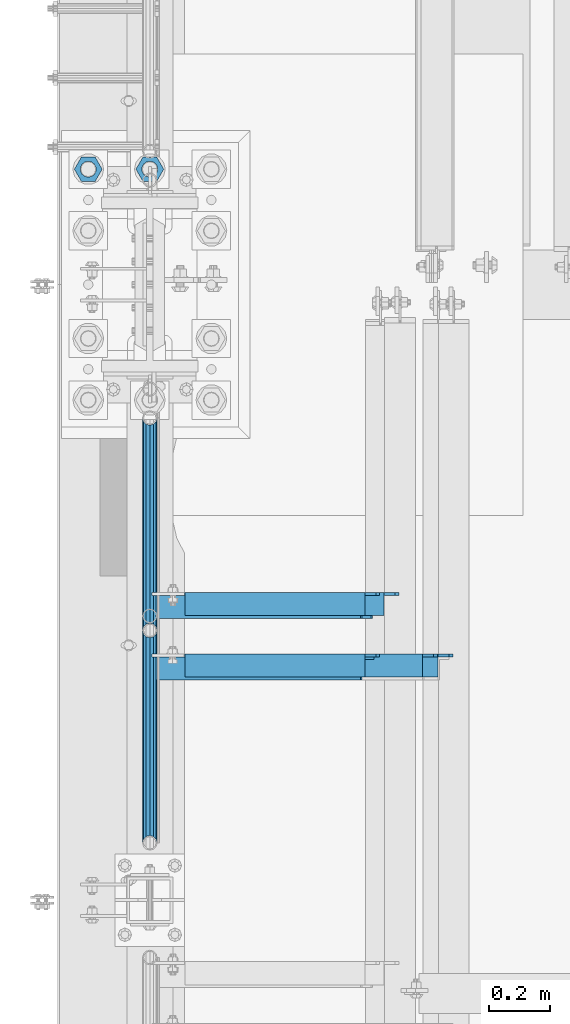
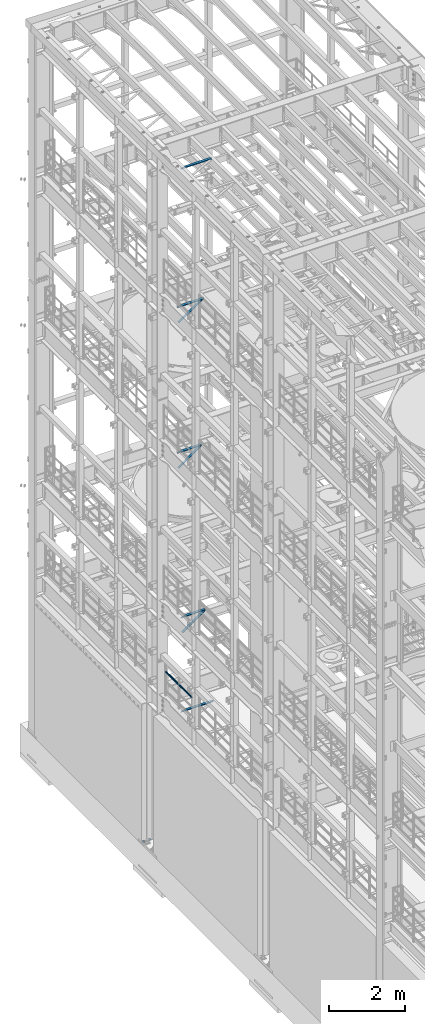
# One storey, part 1286 of 1876: 9 beams, 3 members, 10 elements without a shape of their own.
"""IFC2X3 building model written with IfcOpenShell, lengths in millimetres."""

from ifc_helpers import new_model, si_unit, frame, origin_with_axes, place, context, subcontext, project, spatial, faceted_brep, material, type_object, element, aggregate, save


model = new_model("IFC2X3")

# Units and contexts
model_context = context("Model", 3, precision=1e-05, world=origin_with_axes())
body_context = subcontext(model_context, "Body", "Model", "MODEL_VIEW")
ifc_project = project(units=[si_unit("LENGTHUNIT", "METRE", prefix="MILLI"), si_unit("AREAUNIT", "SQUARE_METRE"), si_unit("VOLUMEUNIT", "CUBIC_METRE"), si_unit("MASSUNIT", "GRAM", prefix="KILO"), si_unit("TIMEUNIT", "SECOND"), si_unit("PLANEANGLEUNIT", "RADIAN"), si_unit("SOLIDANGLEUNIT", "STERADIAN"), si_unit("THERMODYNAMICTEMPERATUREUNIT", "DEGREE_CELSIUS"), si_unit("LUMINOUSINTENSITYUNIT", "LUMEN")], contexts=[model_context])

# Site, building, storey
site_placement = place(None, origin_with_axes())
site = spatial("IfcSite", under=ifc_project, at=site_placement, CompositionType="ELEMENT")
building_placement = place(site_placement, origin_with_axes())
building = spatial("IfcBuilding", under=site, at=building_placement, Name="Undefined", CompositionType="ELEMENT")
storey_placement = place(building_placement, origin_with_axes())
storey = spatial("IfcBuildingStorey", under=building, at=storey_placement, Name="Undefined", CompositionType="ELEMENT", Elevation=0.0)

# Assembly, beams
assembly_1_placement = place(storey_placement, origin_with_axes())
assembly_1 = element("IfcElementAssembly", 1, at=assembly_1_placement, inside=storey, Name="RAIL", AssemblyPlace="NOTDEFINED", PredefinedType="RIGID_FRAME")
ifc_material_1 = material()
beam_type_1 = type_object("IfcBeamType", Name="PIPE1-1/2SCH40", PredefinedType="NOTDEFINED")
beam_1_placement = place(assembly_1_placement, frame((6.68023858452216e-10, 7179.9096633614, 5902.3368245991), z_axis=(0.0, 7.91400000045761e-06, -0.999999999968684), x_axis=(0.0, -0.999999999968684, -7.91400000071008e-06)))
beam_1 = element("IfcBeam", 2, at=beam_1_placement, type_object=beam_type_1, material=ifc_material_1, Name="RAIL", ObjectType="PIPE1-1/2SCH40", context=body_context, shape_type="Brep", body=[
    faceted_brep([(0.0, 24.1299999999992, 0.0), (12.0648982924813, 20.8971929933186, -12.0650000000005), (12.065101708381, 20.8971929933186, 12.0650000000005), (12.065101708381, -20.8971929933186, 12.0650000000005), (12.0648982924813, -20.8971929933186, -12.0650000000005), (0.0, -24.1299999999992, 0.0), (20.897369157401, -12.0649999999996, 20.8971929933205), (20.8973267454676, -12.0649999999277, 15.8661214312533), (15.2546577467156, -17.7076214311801, 10.223500000001), (12.5151929933249, -20.4470000000001, 0.0), (15.2544853785057, -17.7076214311801, -10.2235000000001), (20.8970592426604, -12.0649999999277, -15.8661214312533), (20.8970168307269, -12.0649999999996, -20.8971929933195), (24.1298276326506, 0.0, -20.447000000001), (24.1297965849608, 0.0, -24.130000000001), (21.390472156676, -10.2235000000001, -17.7076214311819), (21.3904721567151, 10.2235000000001, -17.7076214311819), (20.8970592426604, 12.0650000000714, -15.8661214311096), (20.8970168307269, 12.0649999999996, -20.8971929933195), (15.2544853786503, 17.7076214311801, -10.2235000000001), (12.5151929933249, 20.4470000000001, 0.0), (15.2546577468602, 17.7076214311801, 10.223500000001), (20.8973267454676, 12.0650000000714, 15.8661214311096), (20.897369157401, 12.0649999999996, 20.8971929933205), (21.3907707072121, 10.2235000000001, 17.7076214311819), (24.1301723690713, 7.18500814400613e-11, 20.447000000001), (24.1302034167611, 7.18500814400613e-11, 24.1300000000019), (21.390770707173, -10.2235000000001, 17.7076214311819), (701.33983170571, 24.1300000000001, -1.45519152283669e-11), (689.27472999733, 20.8971929933186, -12.0650000000151), (680.442462548309, 12.0649999999996, -20.8971929933323), (701.33983170571, -24.1299999999283, -1.45519152283669e-11), (689.27472999733, -20.8971929933186, -12.0650000000151), (689.27493341323, -20.8971929933186, 12.0649999999878), (680.442814874983, -12.0649999999996, 20.8971929933068), (680.442462548309, -12.0649999999996, -20.8971929933323), (677.20962828895, 0.0, -24.1300000000147), (679.949060998498, 10.2235000000001, -17.7076214311946), (677.20965933664, 0.0, -20.4470000000147), (680.442504960242, 12.0650000000714, -15.8661214311223), (680.442504960242, -12.0649999999277, -15.866121431266), (679.949060998536, -10.2235000000001, -17.7076214311946), (686.085173958994, -17.7076214311801, -10.2235000000137), (688.824638712016, -20.4470000000001, -1.36424205265939e-11), (686.085346327204, -17.7076214311801, 10.2234999999873), (680.44277246305, -12.0649999999277, 15.8661214312397), (679.949359549034, -10.2235000000001, 17.7076214311674), (677.210004073059, 2.72848410531878e-12, 20.4469999999883), (677.210035120749, 2.72848410531878e-12, 24.1299999999883), (680.442814874983, 12.0649999999996, 20.8971929933068), (689.27493341323, 20.8971929933186, 12.0649999999878), (680.44277246305, 12.0650000000714, 15.866121431096), (686.085346327061, 17.7076214311801, 10.2234999999873), (688.824638711873, 20.4470000000001, -1.36424205265939e-11), (686.085173958852, 17.7076214311801, -10.2235000000137), (679.949359548996, 10.2235000000001, 17.7076214311674)], [[[0, 1, 2]], [[3, 4, 5]], [[6, 7, 8, 9, 10, 11, 12, 4, 3]], [[13, 14, 12, 11, 15]], [[16, 17, 18, 14, 13]], [[2, 1, 18, 17, 19, 20, 21, 22, 23]], [[23, 22, 24, 25, 26]], [[26, 25, 27, 7, 6]], [[1, 0, 28, 29]], [[18, 1, 29, 30]], [[31, 32, 33]], [[6, 3, 33, 34]], [[3, 5, 31, 33]], [[5, 4, 32, 31]], [[4, 12, 35, 32]], [[12, 14, 36, 35]], [[14, 18, 30, 36]], [[37, 38, 36, 30, 39]], [[40, 35, 36, 38, 41]], [[33, 32, 35, 40, 42, 43, 44, 45, 34]], [[34, 45, 46, 47, 48]], [[26, 6, 34, 48]], [[2, 23, 49, 50]], [[23, 26, 48, 49]], [[0, 2, 50, 28]], [[28, 50, 29]], [[49, 51, 52, 53, 54, 39, 30, 29, 50]], [[48, 47, 55, 51, 49]], [[25, 24, 55, 47]], [[55, 24, 22, 21, 52, 51]], [[21, 20, 53, 52]], [[20, 19, 54, 53]], [[19, 17, 16, 37, 39, 54]], [[16, 13, 38, 37]], [[13, 15, 41, 38]], [[41, 15, 11, 10, 42, 40]], [[10, 9, 43, 42]], [[9, 8, 44, 43]], [[8, 7, 27, 46, 45, 44]], [[27, 25, 47, 46]]]),
])
beam_2_placement = place(assembly_1_placement, frame((7.03721525496803e-11, 6478.5698316807, 5902.33091229485), z_axis=(0.0, 7.91400000045761e-06, -0.999999999968684), x_axis=(0.0, -0.999999999968684, -7.91400000071008e-06)))
beam_2 = element("IfcBeam", 3, at=beam_2_placement, type_object=beam_type_1, material=ifc_material_1, Name="RAIL", ObjectType="PIPE1-1/2SCH40", context=body_context, shape_type="Brep", body=[
    faceted_brep([(0.0, 24.1299999999992, 0.0), (12.0648982924813, 20.8971929933186, -12.0650000000005), (12.065101708381, 20.8971929933186, 12.0650000000005), (12.065101708381, -20.8971929933186, 12.0650000000005), (12.0648982924813, -20.8971929933186, -12.0650000000005), (0.0, -24.1299999999992, 0.0), (20.897369157401, -12.0649999999996, 20.8971929933205), (20.8973267454676, -12.0649999999277, 15.8661214312533), (15.2546577467156, -17.7076214311801, 10.223500000001), (12.5151929933249, -20.4470000000001, 0.0), (15.2544853785057, -17.7076214311801, -10.2235000000001), (20.8970592426604, -12.0649999999277, -15.8661214312533), (20.8970168307269, -12.0649999999996, -20.8971929933195), (24.1298276326506, 0.0, -20.447000000001), (24.1297965849608, 0.0, -24.130000000001), (21.390472156676, -10.2235000000001, -17.7076214311819), (21.3904721567151, 10.2235000000001, -17.7076214311819), (20.8970592426604, 12.0650000000714, -15.8661214311096), (20.8970168307269, 12.0649999999996, -20.8971929933195), (15.2544853786503, 17.7076214311801, -10.2235000000001), (12.5151929933249, 20.4470000000001, 0.0), (15.2546577468602, 17.7076214311801, 10.223500000001), (20.8973267454676, 12.0650000000714, 15.8661214311096), (20.897369157401, 12.0649999999996, 20.8971929933205), (21.3907707072121, 10.2235000000001, 17.7076214311819), (24.1301723690713, 7.18500814400613e-11, 20.447000000001), (24.1302034167611, 7.18500814400613e-11, 24.1300000000019), (21.390770707173, -10.2235000000001, 17.7076214311819), (701.33983170571, 24.1300000000001, -1.45519152283669e-11), (689.27472999733, 20.8971929933186, -12.0650000000151), (680.442462548309, 12.0649999999996, -20.8971929933323), (701.33983170571, -24.1299999999283, -1.45519152283669e-11), (689.27472999733, -20.8971929933186, -12.0650000000151), (689.27493341323, -20.8971929933186, 12.0649999999878), (680.442814874983, -12.0649999999996, 20.8971929933068), (680.442462548309, -12.0649999999996, -20.8971929933323), (677.20962828895, 0.0, -24.1300000000147), (679.949060998498, 10.2235000000001, -17.7076214311946), (677.20965933664, 0.0, -20.4470000000147), (680.442504960242, 12.0650000000714, -15.8661214311223), (680.442504960242, -12.0649999999277, -15.866121431266), (679.949060998536, -10.2235000000001, -17.7076214311946), (686.085173958994, -17.7076214311801, -10.2235000000137), (688.824638712016, -20.4470000000001, -1.36424205265939e-11), (686.085346327204, -17.7076214311801, 10.2234999999873), (680.44277246305, -12.0649999999277, 15.8661214312397), (679.949359549034, -10.2235000000001, 17.7076214311674), (677.210004073059, 2.72848410531878e-12, 20.4469999999883), (677.210035120749, 2.72848410531878e-12, 24.1299999999883), (680.442814874983, 12.0649999999996, 20.8971929933068), (689.27493341323, 20.8971929933186, 12.0649999999878), (680.44277246305, 12.0650000000714, 15.866121431096), (686.085346327061, 17.7076214311801, 10.2234999999873), (688.824638711873, 20.4470000000001, -1.36424205265939e-11), (686.085173958852, 17.7076214311801, -10.2235000000137), (679.949359548996, 10.2235000000001, 17.7076214311674)], [[[0, 1, 2]], [[3, 4, 5]], [[6, 7, 8, 9, 10, 11, 12, 4, 3]], [[13, 14, 12, 11, 15]], [[16, 17, 18, 14, 13]], [[2, 1, 18, 17, 19, 20, 21, 22, 23]], [[23, 22, 24, 25, 26]], [[26, 25, 27, 7, 6]], [[1, 0, 28, 29]], [[18, 1, 29, 30]], [[31, 32, 33]], [[6, 3, 33, 34]], [[3, 5, 31, 33]], [[5, 4, 32, 31]], [[4, 12, 35, 32]], [[12, 14, 36, 35]], [[14, 18, 30, 36]], [[37, 38, 36, 30, 39]], [[40, 35, 36, 38, 41]], [[33, 32, 35, 40, 42, 43, 44, 45, 34]], [[34, 45, 46, 47, 48]], [[26, 6, 34, 48]], [[2, 23, 49, 50]], [[23, 26, 48, 49]], [[0, 2, 50, 28]], [[28, 50, 29]], [[49, 51, 52, 53, 54, 39, 30, 29, 50]], [[48, 47, 55, 51, 49]], [[25, 24, 55, 47]], [[55, 24, 22, 21, 52, 51]], [[21, 20, 53, 52]], [[20, 19, 54, 53]], [[19, 17, 16, 37, 39, 54]], [[16, 13, 38, 37]], [[13, 15, 41, 38]], [[41, 15, 11, 10, 42, 40]], [[10, 9, 43, 42]], [[9, 8, 44, 43]], [[8, 7, 27, 46, 45, 44]], [[27, 25, 47, 46]]]),
])
aggregate(assembly_1, [beam_1, beam_2])

# Assembly, member
assembly_2_placement = place(storey_placement, origin_with_axes())
assembly_2 = element("IfcElementAssembly", 4, at=assembly_2_placement, inside=storey, AssemblyPlace="NOTDEFINED", PredefinedType="RIGID_FRAME")
ifc_material_2 = material(Name="STEEL/A36")
member_type = type_object("IfcMemberType", Name="L3X3X3/8", PredefinedType="NOTDEFINED")
member_1_placement = place(assembly_2_placement, frame((21.6869001657126, 6556.375, 17424.2669187563), z_axis=(0.0, -1.0, 0.0), x_axis=(0.822192192147785, 0.0, 0.569209978102299)))
member_1 = element("IfcMember", 5, at=member_1_placement, type_object=member_type, material=ifc_material_2, ObjectType="L3X3X3/8", context=body_context, shape_type="Brep", body=[
    faceted_brep([(24.1351720308776, 38.0999999999403, -38.1000000000004), (24.1351720308776, 38.0999999999403, 38.0999999999999), (887.866654075793, 38.0999999989017, 38.0999999999999), (887.866654075793, 38.0999999989017, -38.1000000000004), (24.135172030894, 28.5749999999462, 38.0999999999999), (887.866654075808, 28.5749999989075, 38.0999999999999), (24.135172030894, 28.5749999999462, -28.5749999999998), (887.866654075808, 28.5749999989075, -28.5749999999998), (24.1351720310122, -38.0999999999985, -28.5749999999998), (887.86665407593, -38.1000000010354, -28.5749999999998), (24.1351720310122, -38.0999999999985, -38.1000000000004), (887.86665407593, -38.1000000010354, -38.1000000000004)], [[[0, 1, 2, 3]], [[1, 4, 5, 2]], [[4, 6, 7, 5]], [[6, 8, 9, 7]], [[8, 10, 11, 9]], [[10, 0, 3, 11]], [[5, 7, 9, 11, 3, 2]], [[10, 8, 6, 4, 1, 0]]]),
])
aggregate(assembly_2, [member_1])

assembly_3_placement = place(storey_placement, origin_with_axes())
assembly_3 = element("IfcElementAssembly", 6, at=assembly_3_placement, inside=storey, AssemblyPlace="NOTDEFINED", PredefinedType="RIGID_FRAME")
member_2_placement = place(assembly_3_placement, frame((22.1939709589552, 6353.175, 7601.73169287095), z_axis=(0.0, -1.0, 0.0), x_axis=(0.812817140855119, 0.0, 0.582518922896166)))
member_2 = element("IfcMember", 7, at=member_2_placement, type_object=member_type, material=ifc_material_2, ObjectType="L3X3X3/8", context=body_context, shape_type="Brep", body=[
    faceted_brep([(24.4135476554111, 38.1000000000058, -38.0999999999999), (24.4135476554111, 38.1000000000058, 38.0999999999999), (855.72322987264, 38.1000000000749, 38.0999999999999), (855.72322987264, 38.1000000000749, -38.0999999999999), (24.4135476554093, 28.5750000000053, 38.0999999999999), (855.723229872639, 28.5750000000744, 38.0999999999999), (24.4135476554093, 28.5750000000053, -28.5749999999998), (855.723229872639, 28.5750000000744, -28.5749999999998), (24.4135476553975, -38.1000000000031, -28.5749999999998), (855.723229872628, -38.0999999999331, -28.5749999999998), (24.4135476553975, -38.1000000000031, -38.0999999999999), (855.723229872628, -38.0999999999331, -38.0999999999999)], [[[0, 1, 2, 3]], [[1, 4, 5, 2]], [[4, 6, 7, 5]], [[6, 8, 9, 7]], [[8, 10, 11, 9]], [[10, 0, 3, 11]], [[5, 7, 9, 11, 3, 2]], [[10, 8, 6, 4, 1, 0]]]),
])
aggregate(assembly_3, [member_2])

assembly_4_placement = place(storey_placement, origin_with_axes())
assembly_4 = element("IfcElementAssembly", 8, at=assembly_4_placement, inside=storey, Name="BRACE", AssemblyPlace="NOTDEFINED", PredefinedType="RIGID_FRAME")
member_3_placement = place(assembly_4_placement, frame((22.1939716658251, 6556.375, 12757.9316674293), z_axis=(0.0, -1.0, 0.0), x_axis=(0.812817140855119, 0.0, 0.582518922896166)))
member_3 = element("IfcMember", 9, at=member_3_placement, type_object=member_type, material=ifc_material_2, Name="BRACE", ObjectType="L3X3X3/8", context=body_context, shape_type="Brep", body=[
    faceted_brep([(855.723229872639, 28.5750000000744, 38.0999999999999), (855.723229872639, 28.5750000000744, -28.5749999999998), (855.723229872628, -38.0999999999331, -28.5749999999998), (855.723229872628, -38.0999999999331, -38.0999999999999), (855.72322987264, 38.1000000000749, -38.0999999999999), (855.72322987264, 38.1000000000749, 38.0999999999999), (24.4135476554093, 28.5750000000053, 38.0999999999999), (24.4135476554093, 28.5750000000053, -28.5749999999998), (24.4135476553975, -38.1000000000031, -28.5749999999998), (24.4135476553975, -38.1000000000031, -38.0999999999999), (24.4135476554111, 38.1000000000058, -38.0999999999999), (24.4135476554111, 38.1000000000058, 38.0999999999999)], [[[0, 1, 2, 3, 4, 5]], [[6, 7, 1, 0]], [[7, 8, 2, 1]], [[8, 9, 3, 2]], [[9, 10, 4, 3]], [[10, 11, 5, 4]], [[11, 6, 0, 5]], [[9, 8, 7, 6, 11, 10]]]),
])
aggregate(assembly_4, [member_3])

# Assembly, beam
assembly_5_placement = place(storey_placement, origin_with_axes())
assembly_5 = element("IfcElementAssembly", 10, at=assembly_5_placement, inside=storey, Name="ANGLE", AssemblyPlace="NOTDEFINED", PredefinedType="RIGID_FRAME")
beam_type_2 = type_object("IfcBeamType", Name="L3X3X3/8", PredefinedType="NOTDEFINED")
beam_3_placement = place(assembly_5_placement, frame((4.51516825708356e-09, 6362.7, 22517.1), z_axis=(0.0, -1.0, 0.0), x_axis=(1.0, 0.0, 0.0)))
beam_3 = element("IfcBeam", 11, at=beam_3_placement, type_object=beam_type_2, material=ifc_material_2, Name="ANGLE", ObjectType="L3X3X3/8", context=body_context, shape_type="Brep", body=[
    faceted_brep([(115.886999817316, 28.5750000000007, 38.0999999999999), (115.886999817316, 38.0999999999985, 38.0999999999999), (115.886998826692, 38.0999999999985, -38.0999999999999), (115.88699882669, 12.699999237062, -38.0999999999999), (115.886998950515, 12.699999237062, -28.5749999999998), (115.88699895052, 28.5750000000007, -28.5749999999998), (38.8937432114558, 12.699999237062, -38.0999999999999), (38.8937433352807, 12.699999237062, -28.5749999999998), (7.14374321145577, -19.050000762938, -38.0999999999999), (7.14374333528067, -19.050000762938, -28.5749999999998), (7.1437499954859, -38.0999999999985, -38.0999999999999), (7.1437499954859, -38.0999999999985, -28.5749999999998), (949.325002419604, 15.8750003814712, -28.5749999999998), (936.625002610339, 28.5750000000007, -28.5749999999998), (900.113000619098, 28.5750000000007, -28.5749999999998), (949.324999995485, -38.0999999999985, -28.5749999999998), (949.325002419604, 3.17500152588036, -28.5749999999998), (900.11300241932, 28.5750000000007, 38.0999999999999), (900.1130024193, 38.0999999999985, 38.0999999999999), (900.113000361957, 38.0999999999985, -38.0999999999999), (900.113000361924, 28.5750001907363, -38.0999999999999), (936.625002353164, 28.5750001907363, -38.0999999999999), (949.325002162429, 15.8750003814712, -38.0999999999999), (949.325002162429, 3.17500152588036, -38.0999999999999), (949.324999995485, -38.0999999999985, -38.0999999999999)], [[[0, 1, 2, 3, 4, 5]], [[4, 3, 6, 7]], [[7, 6, 8, 9]], [[8, 10, 11, 9]], [[12, 13, 14, 5, 4, 7, 9, 11, 15, 16]], [[0, 5, 14, 17]], [[1, 0, 17, 18]], [[2, 1, 18, 19]], [[17, 14, 20, 19, 18]], [[13, 21, 20, 14]], [[12, 22, 21, 13]], [[16, 23, 22, 12]], [[10, 8, 6, 3, 2, 19, 20, 21, 22, 23, 24]], [[11, 10, 24, 15]], [[23, 16, 15, 24]]]),
])
aggregate(assembly_5, [beam_3])

assembly_6_placement = place(storey_placement, origin_with_axes())
assembly_6 = element("IfcElementAssembly", 12, at=assembly_6_placement, inside=storey, Name="ANGLE", AssemblyPlace="NOTDEFINED", PredefinedType="RIGID_FRAME")
beam_4_placement = place(assembly_6_placement, frame((-1.44313229599957e-09, 6565.9, 17945.1), z_axis=(0.0, -1.0, 0.0), x_axis=(1.0, 0.0, 0.0)))
beam_4 = element("IfcBeam", 13, at=beam_4_placement, type_object=beam_type_2, material=ifc_material_2, Name="ANGLE", ObjectType="L3X3X3/8", context=body_context, shape_type="Brep", body=[
    faceted_brep([(773.112500001443, 28.5750000000007, 38.0999999999999), (773.112500001443, 28.5750000000007, -28.5749999999998), (773.112500001443, 28.5750000000007, -38.1000000000004), (773.112500001443, 38.0999999999985, -38.1000000000004), (773.112500001443, 38.0999999999985, 38.0999999999999), (809.625001718057, 28.5750000000007, -28.5749999999998), (809.625001718057, 28.5750000000007, -38.1000000000004), (822.325001527322, 15.8750001907356, -28.5749999999998), (822.325001527322, 15.8750001907356, -38.1000000000004), (822.325001527322, -38.1000030517571, -28.5749999999998), (822.325001527322, -38.0999999999985, -38.1000000000004), (115.886999817316, 28.5750000000007, 38.0999999999999), (115.886999817316, 38.0999999999985, 38.0999999999999), (115.886998826692, 38.0999999999985, -38.0999999999999), (115.88699882669, 12.699999237062, -38.0999999999999), (115.886998950515, 12.699999237062, -28.5749999999998), (115.88699895052, 28.5750000000007, -28.5749999999998), (38.8937432114558, 12.699999237062, -38.0999999999999), (38.8937433352807, 12.699999237062, -28.5749999999998), (7.14374321145577, -19.050000762938, -38.0999999999999), (7.14374333528067, -19.050000762938, -28.5749999999998), (7.1437499954859, -38.0999999999985, -38.0999999999999), (7.1437499954859, -38.0999999999985, -28.5749999999998)], [[[0, 1, 2, 3, 4]], [[5, 6, 2, 1]], [[7, 8, 6, 5]], [[9, 10, 8, 7]], [[11, 12, 13, 14, 15, 16]], [[15, 14, 17, 18]], [[18, 17, 19, 20]], [[19, 21, 22, 20]], [[9, 7, 5, 1, 16, 15, 18, 20, 22]], [[1, 0, 11, 16]], [[0, 4, 12, 11]], [[4, 3, 13, 12]], [[17, 14, 13, 3, 2, 6, 8, 10, 21, 19]], [[10, 9, 22, 21]]]),
])
aggregate(assembly_6, [beam_4])

assembly_7_placement = place(storey_placement, origin_with_axes())
assembly_7 = element("IfcElementAssembly", 14, at=assembly_7_placement, inside=storey, Name="ANGLE", AssemblyPlace="NOTDEFINED", PredefinedType="RIGID_FRAME")
beam_5_placement = place(assembly_7_placement, frame((0.0, 6362.7, 8115.3), z_axis=(0.0, -1.0, 0.0), x_axis=(1.0, 0.0, 0.0)))
beam_5 = element("IfcBeam", 15, at=beam_5_placement, type_object=beam_type_2, material=ifc_material_2, Name="ANGLE", ObjectType="L3X3X3/8", context=body_context, shape_type="Brep", body=[
    faceted_brep([(115.886999817316, 28.5750000000007, 38.0999999999999), (115.886999817316, 38.0999999999985, 38.0999999999999), (115.886998826692, 38.0999999999985, -38.0999999999999), (115.88699882669, 12.699999237062, -38.0999999999999), (115.886998950515, 12.699999237062, -28.5749999999998), (115.88699895052, 28.5750000000007, -28.5749999999998), (38.8937432114558, 12.699999237062, -38.0999999999999), (38.8937433352807, 12.699999237062, -28.5749999999998), (7.14374321145577, -19.050000762938, -38.0999999999999), (7.14374333528067, -19.050000762938, -28.5749999999998), (7.1437499954859, -38.0999999999985, -38.0999999999999), (7.1437499954859, -38.0999999999985, -28.5749999999998), (758.825002424117, 15.8750003814712, -28.5749999999998), (746.125002614852, 28.5749999999998, -28.5749999999998), (709.61300062358, 28.5749999999998, -28.5749999999998), (758.824999999999, -38.1000000000004, -28.5749999999998), (758.825002424117, 3.17500152588036, -28.5749999999998), (709.613002423808, 28.5749999999998, 38.1000000000004), (709.613002423808, 38.1000000000004, 38.1000000000004), (709.613000366395, 38.1000000000004, -38.1000000000004), (709.613000366404, 28.5750001907363, -38.1000000000004), (746.125002357676, 28.5750001907363, -38.1000000000004), (758.825002166941, 15.8750003814712, -38.1000000000004), (758.825002166941, 3.17500152588036, -38.1000000000004), (758.824999999999, -38.1000000000004, -38.1000000000004)], [[[0, 1, 2, 3, 4, 5]], [[4, 3, 6, 7]], [[7, 6, 8, 9]], [[8, 10, 11, 9]], [[12, 13, 14, 5, 4, 7, 9, 11, 15, 16]], [[0, 5, 14, 17]], [[1, 0, 17, 18]], [[2, 1, 18, 19]], [[17, 14, 20, 19, 18]], [[13, 21, 20, 14]], [[12, 22, 21, 13]], [[16, 23, 22, 12]], [[10, 8, 6, 3, 2, 19, 20, 21, 22, 23, 24]], [[11, 10, 24, 15]], [[23, 16, 15, 24]]]),
])
aggregate(assembly_7, [beam_5])

assembly_8_placement = place(storey_placement, origin_with_axes())
assembly_8 = element("IfcElementAssembly", 16, at=assembly_8_placement, inside=storey, Name="ANGLE", AssemblyPlace="NOTDEFINED", PredefinedType="RIGID_FRAME")
beam_6_placement = place(assembly_8_placement, frame((0.0, 6362.7, 5092.7), z_axis=(0.0, -1.0, 0.0), x_axis=(1.0, 0.0, 0.0)))
beam_6 = element("IfcBeam", 17, at=beam_6_placement, type_object=beam_type_2, material=ifc_material_2, Name="ANGLE", ObjectType="L3X3X3/8", context=body_context, shape_type="Brep", body=[
    faceted_brep([(115.886999817316, 28.5750000000007, 38.0999999999999), (115.886999817316, 38.0999999999985, 38.0999999999999), (115.886998826692, 38.0999999999985, -38.0999999999999), (115.88699882669, 12.699999237062, -38.0999999999999), (115.886998950515, 12.699999237062, -28.5749999999998), (115.88699895052, 28.5750000000007, -28.5749999999998), (38.8937432114558, 12.699999237062, -38.0999999999999), (38.8937433352807, 12.699999237062, -28.5749999999998), (7.14374321145577, -19.050000762938, -38.0999999999999), (7.14374333528067, -19.050000762938, -28.5749999999998), (7.1437499954859, -38.0999999999985, -38.0999999999999), (7.1437499954859, -38.0999999999985, -28.5749999999998), (1000.12500242412, 15.8750003814712, -28.5749999999998), (987.425002614851, 28.5749999999998, -28.5749999999998), (950.913000303442, 28.5749999999998, -28.5749999999998), (1000.12500001551, -38.1000000000004, -28.5749999999998), (1000.12500242412, 3.17500152588036, -28.5749999999998), (950.913001170238, 28.5749999999998, 38.0999999999999), (950.913001170238, 38.1000000000004, 38.0999999999999), (950.913000179614, 38.1000000000004, -38.0999999999999), (950.913000366403, 28.5750001907363, -38.0999999999999), (987.425002357675, 28.5750001907363, -38.0999999999999), (1000.12500216694, 15.8750003814712, -38.0999999999999), (1000.12500216694, 3.17500152588036, -38.0999999999999), (1000.12500001551, -38.1000000000004, -38.0999999999999)], [[[0, 1, 2, 3, 4, 5]], [[4, 3, 6, 7]], [[7, 6, 8, 9]], [[8, 10, 11, 9]], [[12, 13, 14, 5, 4, 7, 9, 11, 15, 16]], [[0, 5, 14, 17]], [[1, 0, 17, 18]], [[2, 1, 18, 19]], [[17, 14, 20, 19, 18]], [[13, 21, 20, 14]], [[12, 22, 21, 13]], [[16, 23, 22, 12]], [[10, 8, 6, 3, 2, 19, 20, 21, 22, 23, 24]], [[11, 10, 24, 15]], [[23, 16, 15, 24]]]),
])
aggregate(assembly_8, [beam_6])

assembly_9_placement = place(storey_placement, origin_with_axes())
assembly_9 = element("IfcElementAssembly", 18, at=assembly_9_placement, inside=storey, Name="ANGLE", AssemblyPlace="NOTDEFINED", PredefinedType="RIGID_FRAME")
beam_7_placement = place(assembly_9_placement, frame((-8.61482369428009e-09, 6565.9, 13271.5), z_axis=(0.0, -1.0, 0.0), x_axis=(1.0, 0.0, 0.0)))
beam_7 = element("IfcBeam", 19, at=beam_7_placement, type_object=beam_type_2, material=ifc_material_2, Name="ANGLE", ObjectType="L3X3X3/8", context=body_context, shape_type="Brep", body=[
    faceted_brep([(115.886999817316, 28.5750000000007, 38.0999999999999), (115.886999817316, 38.0999999999985, 38.0999999999999), (115.886998826692, 38.0999999999985, -38.0999999999999), (115.88699882669, 12.699999237062, -38.0999999999999), (115.886998950515, 12.699999237062, -28.5749999999998), (115.88699895052, 28.5750000000007, -28.5749999999998), (38.8937432114558, 12.699999237062, -38.0999999999999), (38.8937433352807, 12.699999237062, -28.5749999999998), (7.14374321145577, -19.050000762938, -38.0999999999999), (7.14374333528067, -19.050000762938, -28.5749999999998), (7.1437499954859, -38.0999999999985, -38.0999999999999), (7.1437499954859, -38.0999999999985, -28.5749999999998), (758.82500204062, 14.2880005577626, -28.5749999999998), (746.125002396449, 26.9880005321429, -28.5749999999998), (709.613000600291, 26.9880010068428, -28.5749999999998), (709.61300062358, 28.5749999999998, -28.5749999999998), (758.824999999999, -38.1000000000004, -28.5749999999998), (758.825001875526, 1.58799979482319, -28.5749999999998), (709.613002423808, 28.5749999999998, 38.1000000000004), (709.613002423808, 38.1000000000004, 38.1000000000004), (709.613000366395, 38.1000000000004, -38.1000000000004), (709.613000343115, 26.9880010068428, -38.1000000000004), (746.125002139273, 26.9880005321429, -38.1000000000004), (758.825001783445, 14.2880005577626, -38.1000000000004), (758.825001618351, 1.58799979482319, -38.1000000000004), (758.824999999999, -38.1000000000004, -38.1000000000004)], [[[0, 1, 2, 3, 4, 5]], [[4, 3, 6, 7]], [[7, 6, 8, 9]], [[8, 10, 11, 9]], [[12, 13, 14, 15, 5, 4, 7, 9, 11, 16, 17]], [[0, 5, 15, 18]], [[1, 0, 18, 19]], [[2, 1, 19, 20]], [[18, 15, 14, 21, 20, 19]], [[13, 22, 21, 14]], [[12, 23, 22, 13]], [[17, 24, 23, 12]], [[10, 8, 6, 3, 2, 20, 21, 22, 23, 24, 25]], [[11, 10, 25, 16]], [[24, 17, 16, 25]]]),
])
aggregate(assembly_9, [beam_7])

# Assembly, beams
assembly_10_placement = place(storey_placement, origin_with_axes())
assembly_10 = element("IfcElementAssembly", 20, at=assembly_10_placement, inside=storey, Name="TEMPLATE", AssemblyPlace="NOTDEFINED", PredefinedType="RIGID_FRAME")
ifc_material_3 = material(Name="STEEL/A563")
beam_type_3 = type_object("IfcBeamType", Name="2_DIA. HALF_NUT", PredefinedType="NOTDEFINED")
beam_8_placement = place(assembly_10_placement, frame((-203.2, 8000.99999847412, 33.3375), z_axis=(0.0, -1.0, 0.0), x_axis=(0.0, 0.0, -1.0)))
beam_8 = element("IfcBeam", 21, at=beam_8_placement, type_object=beam_type_3, material=ifc_material_3, Name="NUT", ObjectType="2_DIA. HALF_NUT", context=body_context, shape_type="Brep", body=[
    faceted_brep([(0.0, -46.0369987487793, 9.09494701772928e-13), (0.0, -23.0184993743896, -39.869213104248), (25.4, -23.0184993743896, -39.869213104248), (25.4, -46.0369987487793, 9.09494701772928e-13), (0.0, 23.0184993743896, -39.869213104248), (25.4, 23.0184993743896, -39.869213104248), (0.0, 46.0369987487793, -9.09494701772928e-13), (25.4, 46.0369987487793, -9.09494701772928e-13), (0.0, 23.0184993743896, 39.869213104248), (25.4, 23.0184993743896, 39.869213104248), (0.0, -23.0184993743896, 39.869213104248), (25.4, -23.0184993743896, 39.869213104248), (0.0, 0.0, 26.1940002441406), (0.0, 11.3650617044514, 23.5999013092769), (25.4, 11.3650617044514, 23.5999013092769), (25.4, 0.0, 26.1940002441406), (0.0, 20.4791109456437, 16.3316083006703), (25.4, 20.4791109456437, 16.3316083006703), (0.0, 25.5370200498346, 5.82867859874477), (25.4, 25.5370200498346, 5.82867859874477), (0.0, 25.5370200498346, -5.82867859874477), (25.4, 25.5370200498346, -5.82867859874477), (0.0, 20.4791109456437, -16.3316083006703), (25.4, 20.4791109456437, -16.3316083006703), (0.0, 11.3650617044514, -23.5999013092769), (25.4, 11.3650617044514, -23.5999013092769), (0.0, 0.0, -26.1940002441406), (25.4, 0.0, -26.1940002441406), (0.0, -11.3650617044514, -23.5999013092769), (25.4, -11.3650617044514, -23.5999013092769), (0.0, -20.4791109456437, -16.3316083006703), (25.4, -20.4791109456437, -16.3316083006703), (0.0, -25.5370200498346, -5.82867859874477), (25.4, -25.5370200498346, -5.82867859874477), (0.0, -25.5370200498346, 5.82867859874477), (25.4, -25.5370200498346, 5.82867859874477), (0.0, -20.4791109456437, 16.3316083006703), (25.4, -20.4791109456437, 16.3316083006703), (0.0, -11.3650617044514, 23.5999013092769), (25.4, -11.3650617044514, 23.5999013092769)], [[[0, 1, 2, 3]], [[1, 4, 5, 2]], [[4, 6, 7, 5]], [[6, 8, 9, 7]], [[8, 10, 11, 9]], [[10, 0, 3, 11]], [[12, 13, 14, 15]], [[13, 16, 17, 14]], [[16, 18, 19, 17]], [[18, 20, 21, 19]], [[20, 22, 23, 21]], [[22, 24, 25, 23]], [[24, 26, 27, 25]], [[26, 28, 29, 27]], [[28, 30, 31, 29]], [[30, 32, 33, 31]], [[32, 34, 35, 33]], [[34, 36, 37, 35]], [[36, 38, 39, 37]], [[38, 12, 15, 39]], [[5, 7, 9, 11, 3, 2], [17, 19, 21, 23, 25, 27, 29, 31, 33, 35, 37, 39, 15, 14]], [[10, 8, 6, 4, 1, 0], [38, 36, 34, 32, 30, 28, 26, 24, 22, 20, 18, 16, 13, 12]]]),
])
beam_9_placement = place(assembly_10_placement, frame((0.0, 8000.99999847412, 33.3375), z_axis=(0.0, -1.0, 0.0), x_axis=(0.0, 0.0, -1.0)))
beam_9 = element("IfcBeam", 22, at=beam_9_placement, type_object=beam_type_3, material=ifc_material_3, Name="NUT", ObjectType="2_DIA. HALF_NUT", context=body_context, shape_type="Brep", body=[
    faceted_brep([(0.0, -46.0369987487793, 9.09494701772928e-13), (0.0, -23.0184993743896, -39.869213104248), (25.4, -23.0184993743896, -39.869213104248), (25.4, -46.0369987487793, 9.09494701772928e-13), (0.0, 23.0184993743896, -39.869213104248), (25.4, 23.0184993743896, -39.869213104248), (0.0, 46.0369987487793, -9.09494701772928e-13), (25.4, 46.0369987487793, -9.09494701772928e-13), (0.0, 23.0184993743896, 39.869213104248), (25.4, 23.0184993743896, 39.869213104248), (0.0, -23.0184993743896, 39.869213104248), (25.4, -23.0184993743896, 39.869213104248), (0.0, 0.0, 26.1940002441406), (0.0, 11.3650617044514, 23.5999013092769), (25.4, 11.3650617044514, 23.5999013092769), (25.4, 0.0, 26.1940002441406), (0.0, 20.4791109456437, 16.3316083006703), (25.4, 20.4791109456437, 16.3316083006703), (0.0, 25.5370200498346, 5.82867859874477), (25.4, 25.5370200498346, 5.82867859874477), (0.0, 25.5370200498346, -5.82867859874477), (25.4, 25.5370200498346, -5.82867859874477), (0.0, 20.4791109456437, -16.3316083006703), (25.4, 20.4791109456437, -16.3316083006703), (0.0, 11.3650617044514, -23.5999013092769), (25.4, 11.3650617044514, -23.5999013092769), (0.0, 0.0, -26.1940002441406), (25.4, 0.0, -26.1940002441406), (0.0, -11.3650617044514, -23.5999013092769), (25.4, -11.3650617044514, -23.5999013092769), (0.0, -20.4791109456437, -16.3316083006703), (25.4, -20.4791109456437, -16.3316083006703), (0.0, -25.5370200498346, -5.82867859874477), (25.4, -25.5370200498346, -5.82867859874477), (0.0, -25.5370200498346, 5.82867859874477), (25.4, -25.5370200498346, 5.82867859874477), (0.0, -20.4791109456437, 16.3316083006703), (25.4, -20.4791109456437, 16.3316083006703), (0.0, -11.3650617044514, 23.5999013092769), (25.4, -11.3650617044514, 23.5999013092769)], [[[0, 1, 2, 3]], [[1, 4, 5, 2]], [[4, 6, 7, 5]], [[6, 8, 9, 7]], [[8, 10, 11, 9]], [[10, 0, 3, 11]], [[12, 13, 14, 15]], [[13, 16, 17, 14]], [[16, 18, 19, 17]], [[18, 20, 21, 19]], [[20, 22, 23, 21]], [[22, 24, 25, 23]], [[24, 26, 27, 25]], [[26, 28, 29, 27]], [[28, 30, 31, 29]], [[30, 32, 33, 31]], [[32, 34, 35, 33]], [[34, 36, 37, 35]], [[36, 38, 39, 37]], [[38, 12, 15, 39]], [[5, 7, 9, 11, 3, 2], [17, 19, 21, 23, 25, 27, 29, 31, 33, 35, 37, 39, 15, 14]], [[10, 8, 6, 4, 1, 0], [38, 36, 34, 32, 30, 28, 26, 24, 22, 20, 18, 16, 13, 12]]]),
])
aggregate(assembly_10, [beam_8, beam_9])

save(model, "model.ifc")
